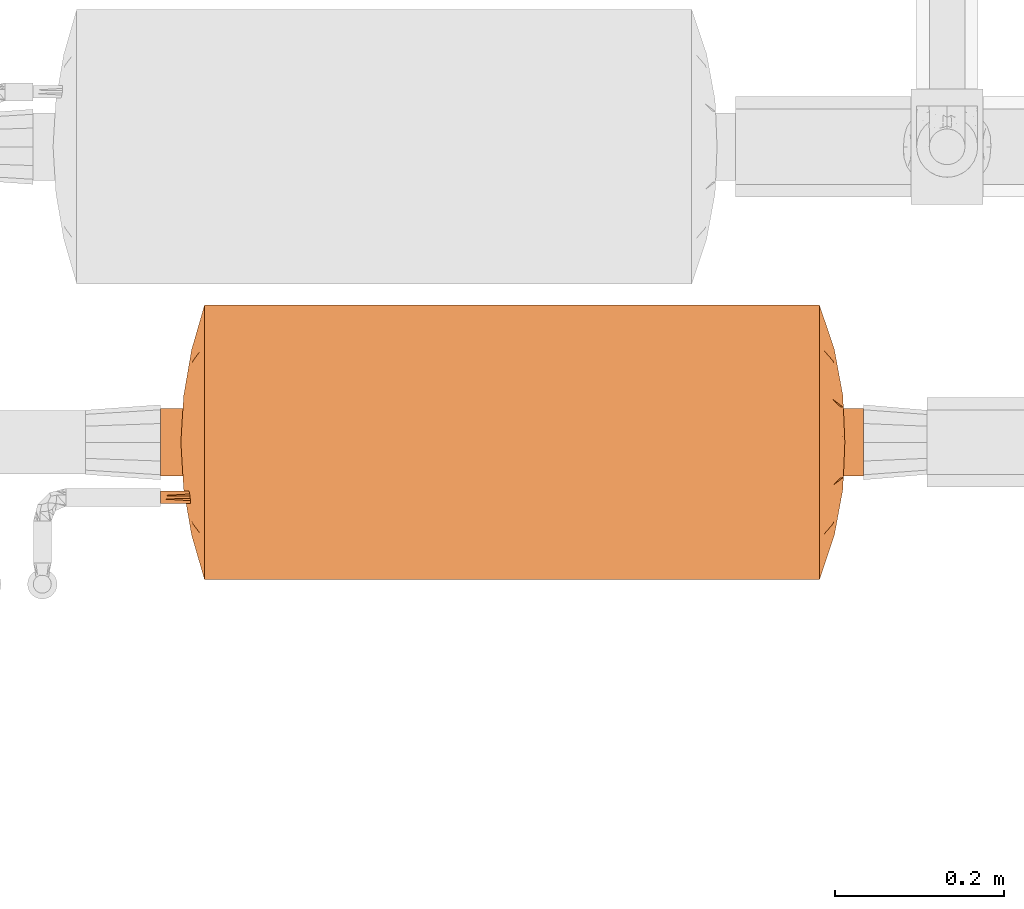
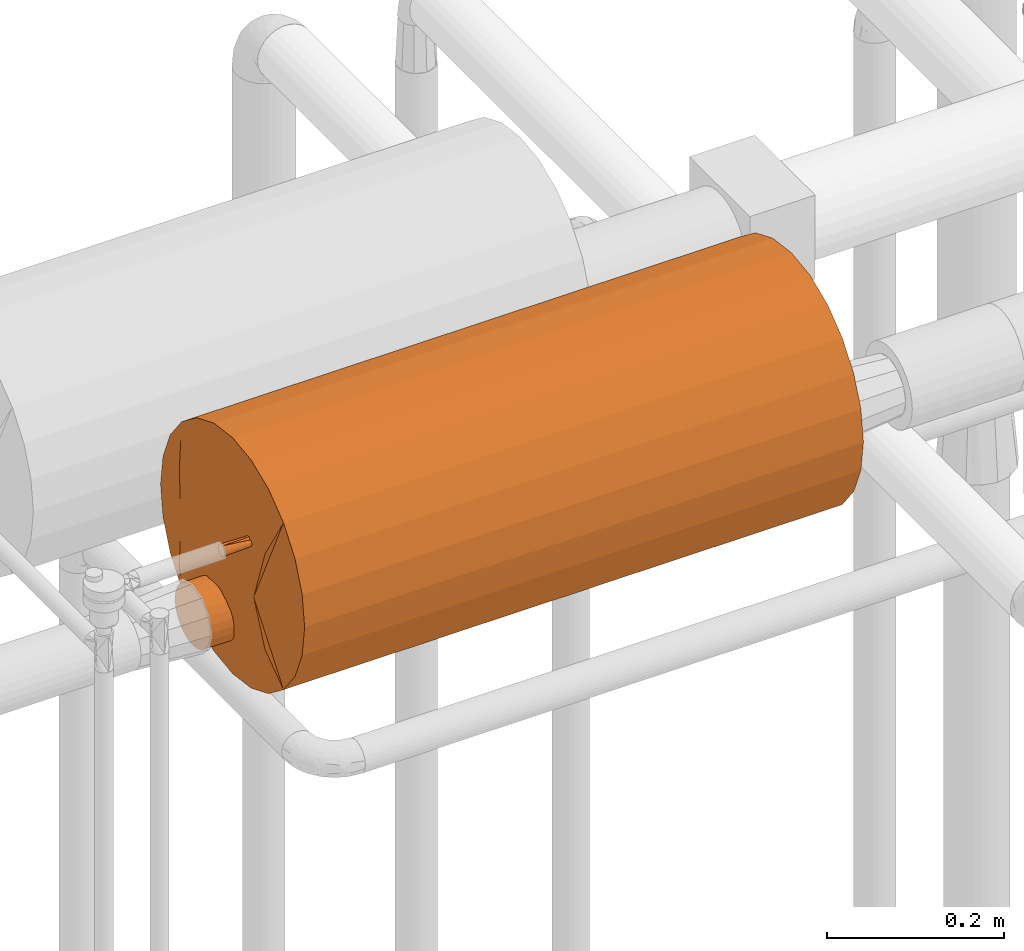
# One storey, part 824 of 827: 1 proxy.
"""IFC2X3 building model written with IfcOpenShell, lengths in millimetres."""

from ifc_helpers import new_model, entity, si_unit, converted_unit, derived_unit, direction, frame, origin, place, context, subcontext, project, spatial, faceted_brep, source, transform, mapped, material, material_list, type_object, type_shapes, element, save


model = new_model("IFC2X3")

# Units and contexts
model_context = context("Model", 3, precision=0.01, world=origin(), true_north=direction((6.12303176911189e-17, 1.0)))
body_context = subcontext(model_context, "Body", "Model", "MODEL_VIEW")
ifc_project = project(units=[si_unit("LENGTHUNIT", "METRE", prefix="MILLI"), si_unit("AREAUNIT", "SQUARE_METRE"), si_unit("VOLUMEUNIT", "CUBIC_METRE"), converted_unit("PLANEANGLEUNIT", "DEGREE", entity("IfcRatioMeasure", 0.0174532925199433), si_unit("PLANEANGLEUNIT", "RADIAN"), dimensions=[0, 0, 0, 0, 0, 0, 0]), si_unit("MASSUNIT", "GRAM", prefix="KILO"), derived_unit("MASSDENSITYUNIT", [(si_unit("MASSUNIT", "GRAM", prefix="KILO"), 1), (si_unit("LENGTHUNIT", "METRE"), -3)]), derived_unit("MOMENTOFINERTIAUNIT", [(si_unit("LENGTHUNIT", "METRE"), 4)]), si_unit("TIMEUNIT", "SECOND"), si_unit("FREQUENCYUNIT", "HERTZ"), si_unit("THERMODYNAMICTEMPERATUREUNIT", "DEGREE_CELSIUS"), derived_unit("THERMALTRANSMITTANCEUNIT", [(si_unit("MASSUNIT", "GRAM", prefix="KILO"), 1), (si_unit("THERMODYNAMICTEMPERATUREUNIT", "KELVIN"), -1), (si_unit("TIMEUNIT", "SECOND"), -3)]), derived_unit("VOLUMETRICFLOWRATEUNIT", [(si_unit("LENGTHUNIT", "METRE"), 3), (si_unit("TIMEUNIT", "SECOND"), -1)]), derived_unit("MASSFLOWRATEUNIT", [(si_unit("MASSUNIT", "GRAM", prefix="KILO"), 1), (si_unit("TIMEUNIT", "SECOND"), -1)]), derived_unit("ROTATIONALFREQUENCYUNIT", [(si_unit("TIMEUNIT", "SECOND"), -1)]), si_unit("ELECTRICCURRENTUNIT", "AMPERE"), si_unit("ELECTRICVOLTAGEUNIT", "VOLT"), si_unit("POWERUNIT", "WATT"), si_unit("FORCEUNIT", "NEWTON", prefix="KILO"), si_unit("ILLUMINANCEUNIT", "LUX"), si_unit("LUMINOUSFLUXUNIT", "LUMEN"), si_unit("LUMINOUSINTENSITYUNIT", "CANDELA"), derived_unit("USERDEFINED", [(si_unit("MASSUNIT", "GRAM", prefix="KILO"), -1), (si_unit("LENGTHUNIT", "METRE"), -2), (si_unit("TIMEUNIT", "SECOND"), 3), (si_unit("LUMINOUSFLUXUNIT", "LUMEN"), 1)]), derived_unit("LINEARVELOCITYUNIT", [(si_unit("LENGTHUNIT", "METRE"), 1), (si_unit("TIMEUNIT", "SECOND"), -1)]), si_unit("PRESSUREUNIT", "PASCAL"), derived_unit("USERDEFINED", [(si_unit("LENGTHUNIT", "METRE"), -2), (si_unit("MASSUNIT", "GRAM", prefix="KILO"), 1), (si_unit("TIMEUNIT", "SECOND"), -2)]), derived_unit("LINEARFORCEUNIT", [(si_unit("MASSUNIT", "GRAM", prefix="KILO"), 1), (si_unit("LENGTHUNIT", "METRE"), 1), (si_unit("TIMEUNIT", "SECOND"), -2), (si_unit("LENGTHUNIT", "METRE"), -1)]), derived_unit("PLANARFORCEUNIT", [(si_unit("MASSUNIT", "GRAM", prefix="KILO"), 1), (si_unit("LENGTHUNIT", "METRE"), 1), (si_unit("TIMEUNIT", "SECOND"), -2), (si_unit("LENGTHUNIT", "METRE"), -2)])], contexts=[model_context])

# Site, building, storey
site_placement = place(None, origin())
site = spatial("IfcSite", under=ifc_project, at=site_placement, CompositionType="ELEMENT")
building_placement = place(site_placement, origin())
building = spatial("IfcBuilding", under=site, at=building_placement, CompositionType="ELEMENT")
storey_placement = place(building_placement, frame((0.0, 0.0, 28200.0)))
storey = spatial("IfcBuildingStorey", under=building, at=storey_placement, Name="08", CompositionType="ELEMENT", Elevation=28200.0)

# Proxy
ifc_material_1 = material()
ifc_material_2 = material()
ifc_material_3 = material()
ifc_material_list = material_list([ifc_material_1, ifc_material_2, ifc_material_3])
building_element_proxy_type = type_object("IfcBuildingElementProxyType", Name=":Dy80", PredefinedType="NOTDEFINED", material=ifc_material_1)
shared_shape = source(origin(), body_context, "Body", "Brep", [
    faceted_brep([(68.75, -416.0, 58.5), (70.3, -416.0, 59.7), (71.5, -416.0, 61.25), (72.24, -416.0, 63.06), (72.5, -416.0, 65.0), (72.24, -416.0, 66.94), (71.5, -416.0, 68.75), (70.3, -416.0, 70.3), (68.75, -416.0, 71.5), (66.94, -416.0, 72.24), (65.0, -416.0, 72.5), (63.06, -416.0, 72.24), (61.25, -416.0, 71.5), (59.7, -416.0, 70.3), (58.5, -416.0, 68.75), (57.76, -416.0, 66.94), (57.5, -416.0, 65.0), (57.76, -416.0, 63.06), (58.5, -416.0, 61.25), (59.7, -416.0, 59.7), (61.25, -416.0, 58.5), (63.06, -416.0, 57.76), (65.0, -416.0, 57.5), (66.94, -416.0, 57.76), (65.0, 0.0, 72.5), (66.94, 0.0, 72.24), (68.75, 0.0, 71.5), (70.3, 0.0, 70.3), (71.5, 0.0, 68.75), (72.24, 0.0, 66.94), (72.5, 0.0, 65.0), (72.24, 0.0, 63.06), (71.5, 0.0, 61.25), (70.3, 0.0, 59.7), (68.75, 0.0, 58.5), (66.94, 0.0, 57.76), (65.0, 0.0, 57.5), (63.06, 0.0, 57.76), (61.25, 0.0, 58.5), (59.7, 0.0, 59.7), (58.5, 0.0, 61.25), (57.76, 0.0, 63.06), (57.5, 0.0, 65.0), (57.76, 0.0, 66.94), (58.5, 0.0, 68.75), (59.7, 0.0, 70.3), (61.25, 0.0, 71.5), (63.06, 0.0, 72.24), (72.5, -320.38, 65.0), (65.49, -181.32, 57.52), (72.5, -95.62, 65.0), (72.5, -208.0, 65.0), (72.5, -224.75, 65.0), (65.0, -272.56, 57.5), (57.5, -320.38, 65.0), (57.5, -224.75, 65.0), (57.5, -208.0, 65.0), (65.0, -84.55, 57.5), (57.5, -95.62, 65.0), (65.0, -84.55, 72.5), (65.0, -272.56, 72.5), (64.51, -181.32, 72.48)], [[[0, 1, 2, 3, 4, 5, 6, 7, 8, 9, 10, 11, 12, 13, 14, 15, 16, 17, 18, 19, 20, 21, 22, 23]], [[24, 25, 26, 27, 28, 29, 30, 31, 32, 33, 34, 35, 36, 37, 38, 39, 40, 41, 42, 43, 44, 45, 46, 47]], [[48, 1, 0]], [[49, 50, 51, 52]], [[53, 54, 55, 56]], [[57, 38, 37]], [[2, 1, 48]], [[36, 57, 37]], [[21, 53, 22]], [[19, 18, 54]], [[58, 40, 39]], [[35, 34, 57]], [[58, 57, 49]], [[58, 42, 41]], [[17, 16, 54]], [[58, 49, 56]], [[18, 17, 54]], [[56, 49, 53]], [[48, 4, 3]], [[31, 30, 50]], [[38, 57, 39]], [[33, 57, 34]], [[53, 52, 48]], [[40, 58, 41]], [[33, 32, 50]], [[49, 57, 50]], [[50, 32, 31]], [[58, 39, 57]], [[52, 53, 49]], [[2, 48, 3]], [[35, 57, 36]], [[22, 53, 23]], [[54, 20, 19]], [[53, 48, 23]], [[0, 23, 48]], [[54, 53, 21]], [[21, 20, 54]], [[33, 50, 57]], [[13, 12, 54]], [[59, 26, 25]], [[14, 13, 54]], [[24, 59, 25]], [[9, 60, 10]], [[50, 28, 27]], [[47, 46, 59]], [[61, 58, 56, 55]], [[60, 55, 54]], [[50, 59, 61]], [[50, 30, 29]], [[5, 4, 48]], [[48, 7, 6]], [[48, 6, 5]], [[54, 16, 15]], [[43, 42, 58]], [[60, 51, 61]], [[50, 61, 51]], [[59, 46, 45]], [[26, 59, 27]], [[45, 44, 58]], [[60, 48, 52, 51]], [[61, 59, 58]], [[58, 44, 43]], [[59, 50, 27]], [[60, 61, 55]], [[14, 54, 15]], [[10, 60, 11]], [[47, 59, 24]], [[48, 8, 7]], [[60, 54, 11]], [[12, 11, 54]], [[9, 48, 60]], [[9, 8, 48]], [[28, 50, 29]], [[45, 58, 59]]]),
    faceted_brep([(10.24, -416.0, -103.64), (19.88, -416.0, -99.64), (28.17, -416.0, -93.28), (34.52, -416.0, -85.0), (38.52, -416.0, -75.35), (39.88, -416.0, -65.0), (38.52, -416.0, -54.65), (34.52, -416.0, -45.0), (28.17, -416.0, -36.72), (19.88, -416.0, -30.36), (10.24, -416.0, -26.36), (-0.12, -416.0, -25.0), (-10.47, -416.0, -26.36), (-20.12, -416.0, -30.36), (-28.4, -416.0, -36.72), (-34.76, -416.0, -45.0), (-38.75, -416.0, -54.65), (-40.12, -416.0, -65.0), (-38.75, -416.0, -75.35), (-34.76, -416.0, -85.0), (-28.4, -416.0, -93.28), (-20.12, -416.0, -99.64), (-10.47, -416.0, -103.64), (-0.12, -416.0, -105.0), (-0.12, 416.0, -25.0), (10.24, 416.0, -26.36), (19.88, 416.0, -30.36), (28.17, 416.0, -36.72), (34.52, 416.0, -45.0), (38.52, 416.0, -54.65), (39.88, 416.0, -65.0), (38.52, 416.0, -75.35), (34.52, 416.0, -85.0), (28.17, 416.0, -93.28), (19.88, 416.0, -99.64), (10.24, 416.0, -103.64), (-0.12, 416.0, -105.0), (-10.47, 416.0, -103.64), (-20.12, 416.0, -99.64), (-28.4, 416.0, -93.28), (-34.76, 416.0, -85.0), (-38.75, 416.0, -75.35), (-40.12, 416.0, -65.0), (-38.75, 416.0, -54.65), (-34.76, 416.0, -45.0), (-28.4, 416.0, -36.72), (-20.12, 416.0, -30.36), (-10.47, 416.0, -26.36), (-37.07, 0.0, -80.31), (-15.42, 0.0, -101.96), (-5.34, -184.0, -104.66), (-24.47, -103.67, -96.73), (-31.85, -184.0, -89.35), (-31.85, 103.67, -89.35), (-24.47, 184.0, -96.73), (24.23, 103.67, -96.73), (31.62, 184.0, -89.35), (24.23, -184.0, -96.73), (31.62, -103.67, -89.35), (-5.34, 103.67, -104.66), (-39.35, 138.45, -72.8), (-40.12, 0.0, -65.0), (-39.41, -146.88, -72.49), (5.1, -103.67, -104.66), (5.1, 184.0, -104.66), (15.19, 0.0, -101.96), (36.84, 0.0, -80.31), (39.88, 0.0, -65.0), (39.17, 146.88, -72.49), (39.11, -138.45, -72.8), (39.88, -25.67, -65.0), (24.23, -184.0, -33.27), (31.62, 0.0, -40.65), (36.84, 184.0, -49.69), (15.19, 0.0, -28.04), (24.23, 103.67, -33.27), (-24.47, 103.67, -33.27), (-31.85, 184.0, -40.65), (-24.47, -184.0, -33.27), (-31.85, -103.67, -40.65), (5.1, 103.67, -25.34), (39.15, -107.63, -57.39), (39.29, 153.03, -58.11), (36.84, -103.67, -49.69), (5.1, -184.0, -25.34), (-15.42, 0.0, -28.04), (-5.34, 184.0, -25.34), (-5.34, -103.67, -25.34), (-37.07, 0.0, -49.69), (-39.41, 146.88, -57.51), (-39.35, -138.45, -57.2)], [[[0, 1, 2, 3, 4, 5, 6, 7, 8, 9, 10, 11, 12, 13, 14, 15, 16, 17, 18, 19, 20, 21, 22, 23]], [[24, 25, 26, 27, 28, 29, 30, 31, 32, 33, 34, 35, 36, 37, 38, 39, 40, 41, 42, 43, 44, 45, 46, 47]], [[48, 41, 40]], [[49, 50, 22]], [[51, 52, 53, 54]], [[40, 53, 48]], [[49, 38, 37]], [[55, 33, 56]], [[57, 58, 2]], [[54, 49, 51]], [[48, 52, 19]], [[59, 49, 37]], [[41, 48, 60]], [[17, 61, 62]], [[41, 60, 42]], [[40, 39, 53]], [[51, 21, 20]], [[19, 18, 48]], [[63, 0, 23]], [[48, 53, 52]], [[21, 51, 49]], [[34, 33, 55]], [[22, 21, 49]], [[37, 36, 59]], [[49, 59, 50]], [[63, 50, 59, 64]], [[65, 35, 34]], [[59, 36, 64]], [[50, 63, 23]], [[34, 55, 65]], [[66, 32, 31]], [[33, 32, 56]], [[53, 39, 54]], [[56, 66, 58]], [[1, 57, 2]], [[30, 67, 68]], [[65, 0, 63]], [[1, 0, 65]], [[39, 38, 54]], [[58, 3, 2]], [[61, 60, 62]], [[65, 55, 57]], [[22, 50, 23]], [[66, 3, 58]], [[3, 66, 4]], [[36, 35, 64]], [[66, 69, 4]], [[19, 52, 20]], [[52, 51, 20]], [[65, 63, 64]], [[67, 69, 68]], [[69, 5, 4]], [[49, 54, 38]], [[65, 57, 1]], [[58, 57, 55, 56]], [[65, 64, 35]], [[66, 56, 32]], [[62, 48, 18]], [[42, 60, 61]], [[48, 62, 60]], [[17, 62, 18]], [[68, 66, 31]], [[69, 67, 70, 5]], [[66, 68, 69]], [[30, 68, 31]], [[9, 8, 71]], [[72, 73, 28]], [[74, 71, 75]], [[27, 72, 28]], [[74, 26, 25]], [[76, 45, 77]], [[78, 79, 14]], [[72, 27, 75]], [[72, 71, 8]], [[80, 74, 25]], [[5, 70, 81]], [[29, 73, 82]], [[46, 45, 76]], [[27, 26, 75]], [[83, 7, 6]], [[72, 7, 83]], [[72, 83, 73]], [[8, 7, 72]], [[71, 72, 75]], [[25, 24, 80]], [[10, 9, 74]], [[82, 30, 29]], [[74, 80, 84]], [[83, 81, 82]], [[85, 47, 46]], [[80, 24, 86]], [[84, 87, 11]], [[46, 76, 85]], [[88, 44, 43]], [[45, 44, 77]], [[10, 84, 11]], [[77, 88, 79]], [[13, 78, 14]], [[42, 61, 89]], [[85, 12, 87]], [[13, 12, 85]], [[79, 15, 14]], [[90, 17, 16]], [[74, 9, 71]], [[85, 76, 78]], [[28, 73, 29]], [[88, 15, 79]], [[15, 88, 16]], [[82, 81, 70]], [[88, 90, 16]], [[26, 74, 75]], [[24, 47, 86]], [[85, 87, 86]], [[61, 90, 89]], [[87, 12, 11]], [[83, 82, 73]], [[82, 70, 67, 30]], [[83, 6, 81]], [[5, 81, 6]], [[74, 84, 10]], [[87, 84, 80, 86]], [[85, 78, 13]], [[79, 78, 76]], [[85, 86, 47]], [[88, 77, 44]], [[76, 77, 79]], [[89, 88, 43]], [[17, 90, 61]], [[88, 89, 90]], [[42, 89, 43]]]),
    faceted_brep([(-155.82, -365.93, 0.0), (-162.5, -364.0, 0.0), (-161.1, -364.0, -10.66), (-159.69, -364.0, -21.32), (-156.96, -364.0, -42.06), (-135.8, -371.72, 0.0), (-149.15, -367.86, 0.0), (-55.09, -388.69, 0.0), (-68.69, -386.35, 0.0), (-85.05, -378.12, -76.87), (-140.73, -364.0, -81.25), (-109.48, -379.34, 0.0), (-144.79, -364.0, -71.45), (-98.08, -364.0, -127.82), (-96.75, -377.52, -65.95), (-114.9, -364.0, -114.9), (-67.08, -379.71, -84.46), (-82.29, -384.01, 0.0), (-95.89, -381.68, 0.0), (-116.06, -377.43, 0.0), (-122.64, -375.53, 0.0), (-127.82, -364.0, -98.08), (-47.38, -383.12, -78.27), (-41.32, -389.51, 0.0), (82.29, -384.01, 0.0), (114.9, -364.0, -114.9), (95.89, -381.68, 0.0), (-32.54, -386.74, -62.05), (-27.55, -390.33, 0.0), (-81.25, -364.0, -140.73), (161.1, -364.0, -10.66), (162.5, -364.0, 0.0), (155.82, -365.93, 0.0), (149.15, -367.86, 0.0), (135.8, -371.72, 0.0), (156.96, -364.0, -42.06), (159.69, -364.0, -21.32), (-16.83, -384.52, -82.16), (-0.45, -383.35, -90.28), (-6.63, -389.75, -44.58), (81.25, -364.0, -140.73), (85.05, -378.12, -76.87), (67.08, -379.71, -84.46), (148.85, -364.0, -61.65), (116.06, -377.43, 0.0), (140.73, -364.0, -81.25), (96.75, -377.52, -65.95), (68.69, -386.35, 0.0), (109.48, -379.34, 0.0), (127.82, -364.0, -98.08), (-148.85, -364.0, -61.65), (122.64, -375.53, 0.0), (-10.64, -374.91, -126.77), (-29.41, -377.03, -115.39), (-21.03, -364.0, -159.73), (-61.65, -364.0, -148.85), (-42.06, -364.0, -156.96), (0.0, -364.0, -162.5), (28.0, -377.32, -114.56), (32.15, -386.68, -62.66), (15.85, -384.77, -80.88), (-13.77, -391.14, 0.0), (47.38, -383.12, -78.27), (41.32, -389.51, 0.0), (13.77, -391.14, 0.0), (98.08, -364.0, -127.82), (55.09, -388.69, 0.0), (27.55, -390.33, 0.0), (61.65, -364.0, -148.85), (42.06, -364.0, -156.96), (0.0, -391.96, 0.0), (21.03, -364.0, -159.73), (161.1, -364.0, 10.66), (159.69, -364.0, 21.32), (156.96, -364.0, 42.06), (85.05, -378.12, 76.87), (140.73, -364.0, 81.25), (144.79, -364.0, 71.45), (98.08, -364.0, 127.82), (96.75, -377.52, 65.95), (114.9, -364.0, 114.9), (67.08, -379.71, 84.46), (127.82, -364.0, 98.08), (47.38, -383.12, 78.27), (-114.9, -364.0, 114.9), (32.54, -386.74, 62.05), (81.25, -364.0, 140.73), (-156.96, -364.0, 42.06), (-159.69, -364.0, 21.32), (-161.1, -364.0, 10.66), (16.83, -384.52, 82.16), (0.45, -383.35, 90.28), (6.63, -389.75, 44.58), (-81.25, -364.0, 140.73), (-85.05, -378.12, 76.87), (-67.08, -379.71, 84.46), (-148.85, -364.0, 61.65), (-140.73, -364.0, 81.25), (-96.75, -377.52, 65.95), (-127.82, -364.0, 98.08), (148.85, -364.0, 61.65), (10.64, -374.91, 126.77), (29.41, -377.03, 115.39), (21.03, -364.0, 159.73), (61.65, -364.0, 148.85), (42.06, -364.0, 156.96), (0.0, -364.0, 162.5), (-28.0, -377.32, 114.56), (-32.15, -386.68, 62.66), (-15.85, -384.77, 80.88), (-47.38, -383.12, 78.27), (-98.08, -364.0, 127.82), (-61.65, -364.0, 148.85), (-42.06, -364.0, 156.96), (-21.03, -364.0, 159.73), (0.0, -364.0, 0.0)], [[[0, 1, 2, 3, 4, 5, 6]], [[7, 8, 9]], [[10, 11, 12]], [[13, 14, 15]], [[16, 7, 9]], [[15, 17, 18]], [[12, 11, 19, 20]], [[18, 21, 15]], [[22, 23, 16]], [[24, 25, 26]], [[22, 27, 28]], [[29, 16, 9]], [[29, 9, 13]], [[30, 31, 32, 33, 34, 35, 36]], [[13, 9, 14]], [[8, 14, 9]], [[37, 38, 39]], [[10, 21, 11]], [[40, 41, 42]], [[43, 44, 45]], [[11, 21, 18]], [[46, 25, 24]], [[47, 41, 46]], [[48, 49, 45]], [[34, 43, 35]], [[45, 44, 48]], [[20, 50, 12]], [[4, 50, 5]], [[43, 34, 51, 44]], [[5, 50, 20]], [[38, 37, 52]], [[26, 25, 49]], [[49, 48, 26]], [[52, 53, 54]], [[22, 55, 56]], [[22, 16, 55]], [[23, 22, 28]], [[23, 7, 16]], [[54, 57, 52]], [[58, 59, 60]], [[37, 61, 27]], [[62, 42, 63]], [[38, 57, 60]], [[60, 64, 39]], [[65, 46, 41]], [[40, 65, 41]], [[47, 66, 41]], [[42, 41, 66]], [[63, 67, 62]], [[62, 68, 42]], [[42, 66, 63]], [[59, 62, 67]], [[8, 17, 14]], [[16, 29, 55]], [[68, 62, 69]], [[68, 40, 42]], [[15, 14, 17]], [[25, 46, 65]], [[24, 47, 46]], [[53, 37, 27]], [[53, 22, 56]], [[37, 39, 61]], [[61, 28, 27]], [[22, 53, 27]], [[56, 54, 53]], [[62, 59, 58]], [[53, 52, 37]], [[57, 38, 52]], [[59, 64, 60]], [[60, 39, 38]], [[61, 39, 70]], [[60, 57, 71]], [[64, 59, 67]], [[70, 39, 64]], [[58, 60, 71]], [[71, 69, 58]], [[62, 58, 69]], [[32, 31, 72, 73, 74, 34, 33]], [[66, 47, 75]], [[76, 48, 77]], [[78, 79, 80]], [[81, 66, 75]], [[80, 24, 26]], [[77, 48, 44, 51]], [[26, 82, 80]], [[83, 63, 81]], [[17, 84, 18]], [[83, 85, 67]], [[86, 81, 75]], [[86, 75, 78]], [[0, 6, 5, 87, 88, 89, 1]], [[78, 75, 79]], [[47, 79, 75]], [[90, 91, 92]], [[76, 82, 48]], [[93, 94, 95]], [[96, 19, 97]], [[48, 82, 26]], [[98, 84, 17]], [[8, 94, 98]], [[11, 99, 97]], [[5, 96, 87]], [[97, 19, 11]], [[51, 100, 77]], [[74, 100, 34]], [[96, 5, 20, 19]], [[34, 100, 51]], [[91, 90, 101]], [[18, 84, 99]], [[99, 11, 18]], [[101, 102, 103]], [[83, 104, 105]], [[83, 81, 104]], [[63, 83, 67]], [[63, 66, 81]], [[103, 106, 101]], [[107, 108, 109]], [[90, 64, 85]], [[110, 95, 23]], [[91, 106, 109]], [[109, 61, 92]], [[111, 98, 94]], [[93, 111, 94]], [[8, 7, 94]], [[95, 94, 7]], [[23, 28, 110]], [[110, 112, 95]], [[95, 7, 23]], [[108, 110, 28]], [[47, 24, 79]], [[81, 86, 104]], [[112, 110, 113]], [[112, 93, 95]], [[80, 79, 24]], [[84, 98, 111]], [[17, 8, 98]], [[102, 90, 85]], [[102, 83, 105]], [[90, 92, 64]], [[64, 67, 85]], [[83, 102, 85]], [[105, 103, 102]], [[110, 108, 107]], [[102, 101, 90]], [[106, 91, 101]], [[108, 61, 109]], [[109, 92, 91]], [[64, 92, 70]], [[109, 106, 114]], [[61, 108, 28]], [[70, 92, 61]], [[107, 109, 114]], [[114, 113, 107]], [[110, 107, 113]], [[115, 31, 30]], [[115, 30, 36]], [[115, 36, 35]], [[115, 35, 43]], [[115, 43, 45]], [[115, 45, 49]], [[115, 49, 25]], [[115, 25, 65]], [[115, 65, 40]], [[115, 40, 68]], [[115, 68, 69]], [[115, 69, 71]], [[115, 71, 57]], [[115, 57, 54]], [[115, 54, 56]], [[115, 56, 55]], [[115, 55, 29]], [[115, 29, 13]], [[115, 13, 15]], [[115, 15, 21]], [[115, 21, 10]], [[115, 10, 12]], [[115, 12, 50]], [[115, 50, 4]], [[115, 4, 3]], [[115, 3, 2]], [[115, 2, 1]], [[115, 1, 89]], [[115, 72, 31]], [[115, 73, 72]], [[115, 74, 73]], [[115, 100, 74]], [[115, 77, 100]], [[115, 76, 77]], [[115, 82, 76]], [[115, 80, 82]], [[115, 78, 80]], [[115, 86, 78]], [[115, 104, 86]], [[115, 105, 104]], [[115, 103, 105]], [[115, 106, 103]], [[115, 89, 88]], [[115, 88, 87]], [[115, 87, 96]], [[115, 96, 97]], [[115, 97, 99]], [[115, 99, 84]], [[115, 84, 111]], [[115, 111, 93]], [[115, 93, 112]], [[115, 112, 113]], [[115, 113, 114]], [[115, 114, 106]]]),
    faceted_brep([(-69.03, 389.19, 0.0), (-85.06, 380.44, -76.61), (-96.96, 379.53, -66.85), (-151.96, 367.54, 0.0), (-146.69, 369.31, 0.0), (-141.41, 371.08, 0.0), (-133.54, 373.72, 0.0), (-156.96, 364.0, -42.06), (-158.62, 364.0, -29.46), (-159.45, 364.0, -23.17), (-160.28, 364.0, -16.87), (-162.5, 364.0, 0.0), (-42.06, 364.0, -156.96), (-51.54, 378.96, -108.11), (-36.26, 378.67, -115.22), (-66.57, 382.24, -84.52), (-55.4, 391.71, 0.0), (-41.55, 392.28, 0.0), (156.96, 364.0, -42.06), (133.54, 373.72, 0.0), (141.41, 371.08, 0.0), (146.69, 369.31, 0.0), (151.96, 367.54, 0.0), (162.5, 364.0, 0.0), (160.28, 364.0, -16.87), (159.45, 364.0, -23.17), (158.62, 364.0, -29.46), (-140.73, 364.0, -81.25), (-148.85, 364.0, -61.65), (-109.93, 381.64, 0.0), (-127.82, 364.0, -98.08), (109.93, 381.64, 0.0), (148.85, 364.0, -61.65), (140.73, 364.0, -81.25), (-114.9, 364.0, -114.9), (-82.67, 386.68, 0.0), (-125.67, 376.36, 0.0), (51.54, 378.96, -108.11), (41.55, 392.28, 0.0), (66.57, 382.24, -84.52), (114.9, 364.0, -114.9), (96.3, 384.16, 0.0), (127.82, 364.0, -98.08), (125.67, 376.36, 0.0), (81.25, 364.0, -140.73), (85.06, 380.44, -76.61), (-96.3, 384.16, 0.0), (98.08, 364.0, -127.82), (69.03, 389.19, 0.0), (96.96, 379.53, -66.85), (82.67, 386.68, 0.0), (7.51, 388.27, -79.01), (0.0, 394.0, 0.0), (13.85, 393.43, 0.0), (-98.08, 364.0, -127.82), (-81.25, 364.0, -140.73), (-61.65, 364.0, -148.85), (-22.95, 385.16, -92.34), (-13.85, 393.43, 0.0), (-7.04, 391.55, -56.37), (-27.7, 392.85, 0.0), (-42.17, 388.61, -64.85), (55.4, 391.71, 0.0), (36.26, 378.67, -115.22), (42.17, 388.61, -64.85), (61.65, 364.0, -148.85), (-21.03, 364.0, -159.73), (42.06, 364.0, -156.96), (21.03, 364.0, -159.73), (22.95, 385.16, -92.34), (-4.64, 381.32, -111.09), (0.0, 364.0, -162.5), (28.55, 391.9, -45.49), (27.7, 392.85, 0.0), (85.06, 380.44, 76.61), (96.96, 379.53, 66.85), (156.96, 364.0, 42.06), (158.62, 364.0, 29.46), (159.45, 364.0, 23.17), (160.28, 364.0, 16.87), (-148.85, 364.0, 61.65), (-140.73, 364.0, 81.25), (42.06, 364.0, 156.96), (51.54, 378.96, 108.11), (36.26, 378.67, 115.22), (66.57, 382.24, 84.52), (140.73, 364.0, 81.25), (148.85, 364.0, 61.65), (127.82, 364.0, 98.08), (-156.96, 364.0, 42.06), (-160.28, 364.0, 16.87), (-159.45, 364.0, 23.17), (-158.62, 364.0, 29.46), (-96.96, 379.53, 66.85), (-85.06, 380.44, 76.61), (114.9, 364.0, 114.9), (-51.54, 378.96, 108.11), (-66.57, 382.24, 84.52), (-114.9, 364.0, 114.9), (-127.82, 364.0, 98.08), (-81.25, 364.0, 140.73), (-98.08, 364.0, 127.82), (-42.17, 388.61, 64.85), (-22.95, 385.16, 92.34), (-36.26, 378.67, 115.22), (-61.65, 364.0, 148.85), (98.08, 364.0, 127.82), (81.25, 364.0, 140.73), (61.65, 364.0, 148.85), (-7.04, 391.55, 56.37), (-42.06, 364.0, 156.96), (42.17, 388.61, 64.85), (-21.03, 364.0, 159.73), (7.51, 388.27, 79.01), (-4.64, 381.32, 111.09), (22.95, 385.16, 92.34), (21.03, 364.0, 159.73), (0.0, 364.0, 162.5), (0.0, 364.0, 0.0)], [[[0, 1, 2]], [[3, 4, 5, 6, 7, 8, 9, 10, 11]], [[12, 13, 14]], [[15, 16, 17]], [[15, 1, 16]], [[18, 19, 20, 21, 22, 23, 24, 25, 26]], [[27, 28, 29]], [[29, 30, 27]], [[6, 28, 7]], [[31, 32, 33]], [[2, 34, 35]], [[6, 36, 29, 28]], [[32, 19, 18]], [[37, 38, 39]], [[40, 41, 42]], [[31, 43, 19, 32]], [[44, 39, 45]], [[30, 29, 46]], [[44, 45, 47]], [[48, 49, 45]], [[40, 50, 41]], [[51, 52, 53]], [[46, 34, 30]], [[35, 34, 46]], [[31, 42, 41]], [[33, 42, 31]], [[54, 2, 1]], [[55, 54, 1]], [[0, 16, 1]], [[13, 12, 56]], [[57, 58, 59]], [[55, 1, 15]], [[13, 56, 15]], [[47, 45, 49]], [[17, 60, 61]], [[47, 49, 40]], [[39, 62, 45]], [[62, 48, 45]], [[37, 63, 64]], [[39, 44, 65]], [[39, 65, 37]], [[17, 13, 15]], [[38, 62, 39]], [[56, 55, 15]], [[61, 57, 14]], [[61, 60, 57]], [[57, 66, 14]], [[63, 37, 67]], [[37, 65, 67]], [[37, 64, 38]], [[63, 68, 69]], [[70, 57, 59]], [[34, 2, 54]], [[35, 0, 2]], [[48, 50, 49]], [[40, 49, 50]], [[61, 14, 13]], [[17, 61, 13]], [[57, 70, 66]], [[66, 12, 14]], [[57, 60, 58]], [[71, 70, 68]], [[69, 72, 64]], [[63, 67, 68]], [[69, 64, 63]], [[38, 64, 73]], [[72, 51, 53]], [[59, 58, 52]], [[69, 68, 70]], [[51, 70, 59]], [[73, 72, 53]], [[66, 70, 71]], [[51, 59, 52]], [[69, 70, 51]], [[64, 72, 73]], [[51, 72, 69]], [[48, 74, 75]], [[22, 21, 20, 19, 76, 77, 78, 79, 23]], [[29, 80, 81]], [[82, 83, 84]], [[85, 62, 38]], [[85, 74, 62]], [[86, 87, 31]], [[31, 88, 86]], [[19, 87, 76]], [[89, 6, 5, 4, 3, 11, 90, 91, 92]], [[0, 93, 94]], [[75, 95, 50]], [[88, 31, 41]], [[19, 43, 31, 87]], [[96, 17, 97]], [[98, 46, 99]], [[80, 6, 89]], [[100, 97, 94]], [[98, 35, 46]], [[100, 94, 101]], [[6, 80, 29, 36]], [[60, 102, 103]], [[41, 95, 88]], [[50, 95, 41]], [[29, 99, 46]], [[81, 99, 29]], [[101, 94, 93]], [[101, 93, 98]], [[97, 16, 94]], [[16, 0, 94]], [[96, 104, 102]], [[97, 100, 105]], [[97, 105, 96]], [[106, 75, 74]], [[17, 16, 97]], [[107, 106, 74]], [[48, 62, 74]], [[83, 82, 108]], [[109, 52, 58]], [[107, 74, 85]], [[83, 108, 85]], [[104, 96, 110]], [[38, 73, 111]], [[96, 105, 110]], [[96, 102, 17]], [[104, 112, 103]], [[113, 109, 114]], [[38, 83, 85]], [[108, 107, 85]], [[111, 115, 84]], [[113, 53, 52]], [[115, 116, 84]], [[0, 35, 93]], [[98, 93, 35]], [[95, 75, 106]], [[50, 48, 75]], [[117, 114, 112]], [[109, 58, 103]], [[104, 110, 112]], [[103, 102, 104]], [[17, 102, 60]], [[111, 84, 83]], [[38, 111, 83]], [[115, 114, 116]], [[116, 82, 84]], [[115, 111, 73]], [[114, 109, 103]], [[58, 60, 103]], [[115, 73, 53]], [[112, 114, 103]], [[109, 113, 52]], [[114, 117, 116]], [[114, 115, 113]], [[53, 113, 115]], [[118, 18, 26]], [[118, 26, 25]], [[118, 25, 24]], [[118, 24, 23]], [[118, 23, 79]], [[118, 32, 18]], [[118, 33, 32]], [[118, 42, 33]], [[118, 40, 42]], [[118, 47, 40]], [[118, 44, 47]], [[118, 65, 44]], [[118, 67, 65]], [[118, 68, 67]], [[118, 71, 68]], [[118, 66, 71]], [[118, 12, 66]], [[118, 56, 12]], [[118, 55, 56]], [[118, 54, 55]], [[118, 34, 54]], [[118, 30, 34]], [[118, 27, 30]], [[118, 28, 27]], [[118, 7, 28]], [[118, 8, 7]], [[118, 9, 8]], [[118, 10, 9]], [[118, 11, 10]], [[118, 79, 78]], [[118, 78, 77]], [[118, 77, 76]], [[118, 76, 87]], [[118, 87, 86]], [[118, 86, 88]], [[118, 88, 95]], [[118, 95, 106]], [[118, 106, 107]], [[118, 107, 108]], [[118, 108, 82]], [[118, 82, 116]], [[118, 116, 117]], [[118, 117, 112]], [[118, 90, 11]], [[118, 91, 90]], [[118, 92, 91]], [[118, 89, 92]], [[118, 80, 89]], [[118, 81, 80]], [[118, 99, 81]], [[118, 98, 99]], [[118, 101, 98]], [[118, 100, 101]], [[118, 105, 100]], [[118, 110, 105]], [[118, 112, 110]]]),
    faceted_brep([(81.25, -364.0, -140.73), (114.9, -364.0, -114.9), (140.73, -364.0, -81.25), (156.96, -364.0, -42.06), (162.5, -364.0, 0.0), (156.96, -364.0, 42.06), (140.73, -364.0, 81.25), (114.9, -364.0, 114.9), (81.25, -364.0, 140.73), (42.06, -364.0, 156.96), (0.0, -364.0, 162.5), (-42.06, -364.0, 156.96), (-81.25, -364.0, 140.73), (-114.9, -364.0, 114.9), (-140.73, -364.0, 81.25), (-156.96, -364.0, 42.06), (-162.5, -364.0, 0.0), (-156.96, -364.0, -42.06), (-140.73, -364.0, -81.25), (-114.9, -364.0, -114.9), (-81.25, -364.0, -140.73), (-42.06, -364.0, -156.96), (0.0, -364.0, -162.5), (42.06, -364.0, -156.96), (114.9, 364.0, 114.9), (140.73, 364.0, 81.25), (156.96, 364.0, 42.06), (162.5, 364.0, 0.0), (156.96, 364.0, -42.06), (140.73, 364.0, -81.25), (114.9, 364.0, -114.9), (81.25, 364.0, -140.73), (42.06, 364.0, -156.96), (0.0, 364.0, -162.5), (-42.06, 364.0, -156.96), (-81.25, 364.0, -140.73), (-114.9, 364.0, -114.9), (-140.73, 364.0, -81.25), (-156.96, 364.0, -42.06), (-162.5, 364.0, 0.0), (-156.96, 364.0, 42.06), (-140.73, 364.0, 81.25), (-114.9, 364.0, 114.9), (-81.25, 364.0, 140.73), (-42.06, 364.0, 156.96), (0.0, 364.0, 162.5), (42.06, 364.0, 156.96), (81.25, 364.0, 140.73)], [[[0, 1, 2, 3, 4, 5, 6, 7, 8, 9, 10, 11, 12, 13, 14, 15, 16, 17, 18, 19, 20, 21, 22, 23]], [[24, 25, 26, 27, 28, 29, 30, 31, 32, 33, 34, 35, 36, 37, 38, 39, 40, 41, 42, 43, 44, 45, 46, 47]], [[17, 38, 37, 18]], [[36, 19, 18, 37]], [[20, 35, 34, 21]], [[36, 35, 20, 19]], [[21, 34, 33, 22]], [[38, 17, 16, 39]], [[23, 32, 31, 0]], [[30, 1, 0, 31]], [[2, 29, 28, 3]], [[30, 29, 2, 1]], [[3, 28, 27, 4]], [[32, 23, 22, 33]], [[6, 25, 24, 7]], [[8, 47, 46, 9]], [[24, 47, 8, 7]], [[45, 10, 9, 46]], [[4, 27, 26, 5]], [[26, 25, 6, 5]], [[11, 44, 43, 12]], [[42, 13, 12, 43]], [[14, 41, 40, 15]], [[42, 41, 14, 13]], [[15, 40, 39, 16]], [[44, 11, 10, 45]]]),
])
type_shapes(building_element_proxy_type, [shared_shape])
proxy_placement = place(storey_placement, frame((16553.26, 14399.88, 2864.96), z_axis=(0.0, 0.0, 1.0), x_axis=(0.0, -1.0, 0.0)))
element("IfcBuildingElementProxy", 1, at=proxy_placement, inside=storey, type_object=building_element_proxy_type, material=ifc_material_list, Name=":Dy80", ObjectType=":Dy80", context=body_context, shape_type="MappedRepresentation", body=[
    mapped(shared_shape, transform((0.0, 0.0, 0.0), scale=1.0)),
])

save(model, "model.ifc")
